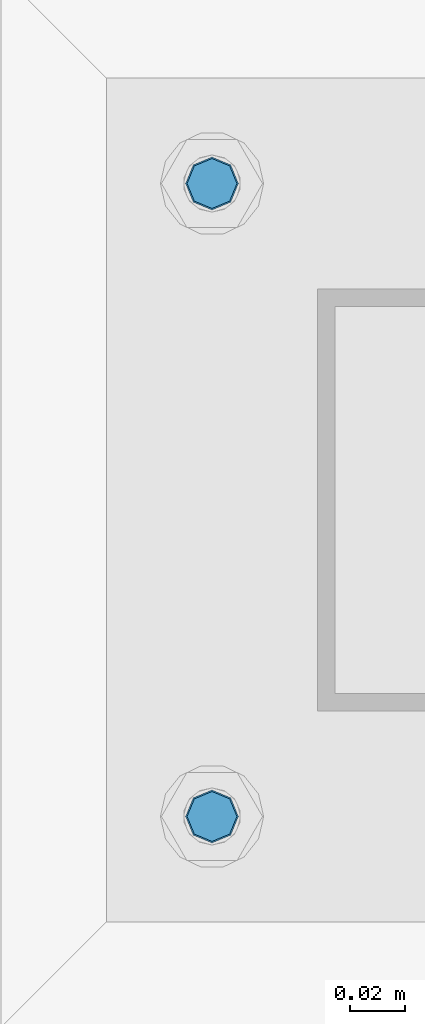
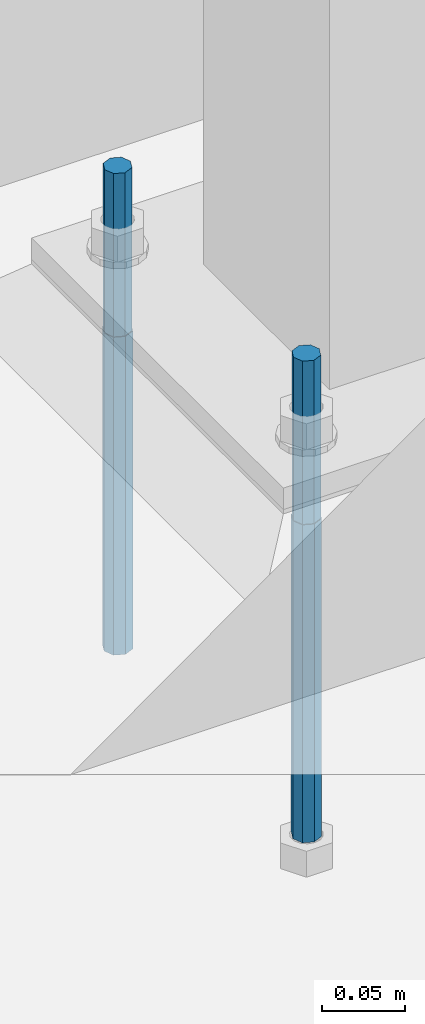
# One storey, part 817 of 1179: 2 beams, 1 element without a shape of its own.
"""IFC2X3 building model written with IfcOpenShell, lengths in millimetres."""

from ifc_helpers import new_model, si_unit, frame, origin_with_axes, place, context, subcontext, project, spatial, faceted_brep, material, type_object, element, aggregate, save


model = new_model("IFC2X3")

# Units and contexts
model_context = context("Model", 3, precision=1e-05, world=origin_with_axes())
body_context = subcontext(model_context, "Body", "Model", "MODEL_VIEW")
ifc_project = project(units=[si_unit("LENGTHUNIT", "METRE", prefix="MILLI"), si_unit("AREAUNIT", "SQUARE_METRE"), si_unit("VOLUMEUNIT", "CUBIC_METRE"), si_unit("MASSUNIT", "GRAM", prefix="KILO"), si_unit("TIMEUNIT", "SECOND"), si_unit("PLANEANGLEUNIT", "RADIAN"), si_unit("SOLIDANGLEUNIT", "STERADIAN"), si_unit("THERMODYNAMICTEMPERATUREUNIT", "DEGREE_CELSIUS"), si_unit("LUMINOUSINTENSITYUNIT", "LUMEN")], contexts=[model_context])

# Site, building, storey
site_placement = place(None, origin_with_axes())
site = spatial("IfcSite", under=ifc_project, at=site_placement, CompositionType="ELEMENT")
building_placement = place(site_placement, origin_with_axes())
building = spatial("IfcBuilding", under=site, at=building_placement, Name="Undefined", CompositionType="ELEMENT")
storey_placement = place(building_placement, origin_with_axes())
storey = spatial("IfcBuildingStorey", under=building, at=storey_placement, Name="Undefined", CompositionType="ELEMENT", Elevation=0.0)

# Assembly, beams
assembly_placement = place(storey_placement, origin_with_axes())
assembly = element("IfcElementAssembly", 1, at=assembly_placement, inside=storey, Name="TEMPLATE", AssemblyPlace="NOTDEFINED", PredefinedType="RIGID_FRAME")
ifc_material = material(Name="STEEL/F1554-GR.36")
beam_type = type_object("IfcBeamType", PredefinedType="NOTDEFINED")
beam_1_placement = place(assembly_placement, frame((26682.7, 2120.9, -812.8), z_axis=(0.0, -1.0, 0.0), x_axis=(0.0, 0.0, -1.0)))
beam_1 = element("IfcBeam", 2, at=beam_1_placement, type_object=beam_type, material=ifc_material, Name="ANCHOR_BOLT", context=body_context, shape_type="Brep", body=[
    faceted_brep([(0.0, -6.73519209080177, -6.73519209080223), (2.95075507493764e-12, -3.62376795237651e-13, -9.52499961853027), (234.949, 0.0, -9.52500000000009), (234.949, -6.73519209080405, -6.73519209080177), (0.0, 6.73519209080177, -6.73519209080223), (234.949, 6.73519209080405, -6.73519209080177), (0.0, 9.52499999999964, 0.0), (234.949, 9.52500000000146, 0.0), (0.0, 6.73519209080177, 6.73519209080223), (234.949, 6.73519209080405, 6.73519209080177), (-9.87109982941227e-13, -3.62376795237651e-13, 9.52499961853027), (234.949, 0.0, 9.52500000000009), (0.0, -6.73519209080177, 6.73519209080223), (234.949, -6.73519209080405, 6.73519209080177), (0.0, -9.52499999999964, 0.0), (234.949, -9.52500000000146, 0.0), (0.0, 6.36396103067818, 6.36396103067909), (0.0, 0.0, 9.0), (0.0, -6.36396103067818, 6.36396103067909), (0.0, -9.0, 0.0), (0.0, -6.36396103067818, -6.36396103067909), (0.0, 0.0, -9.0), (0.0, 6.36396103067818, -6.36396103067909), (0.0, 9.0, 0.0), (-120.65, -6.36396103067818, 6.36396103067909), (-120.65, 0.0, 9.0), (-120.65, 6.36396103067818, 6.36396103067909), (-120.65, 9.0, 0.0), (-120.65, 6.36396103067818, -6.36396103067909), (-120.65, 0.0, -9.0), (-120.65, -6.36396103067818, -6.36396103067909), (-120.65, -9.0, 0.0)], [[[0, 1, 2, 3]], [[1, 4, 5, 2]], [[4, 6, 7, 5]], [[6, 8, 9, 7]], [[8, 10, 11, 9]], [[10, 12, 13, 11]], [[12, 14, 15, 13]], [[2, 5, 7, 9, 11, 13, 15, 3]], [[14, 0, 3, 15]], [[12, 10, 8, 6, 4, 1, 0, 14], [16, 17, 18, 19, 20, 21, 22, 23]], [[24, 25, 26, 27, 28, 29, 30, 31]], [[26, 25, 17, 16]], [[27, 26, 16, 23]], [[28, 27, 23, 22]], [[29, 28, 22, 21]], [[30, 29, 21, 20]], [[31, 30, 20, 19]], [[24, 31, 19, 18]], [[25, 24, 18, 17]]]),
])
beam_2_placement = place(assembly_placement, frame((26682.7, 2349.5, -812.8), z_axis=(0.0, -1.0, 0.0), x_axis=(0.0, 0.0, -1.0)))
beam_2 = element("IfcBeam", 3, at=beam_2_placement, type_object=beam_type, material=ifc_material, Name="ANCHOR_BOLT", context=body_context, shape_type="Brep", body=[
    faceted_brep([(0.0, -6.73519209080177, -6.73519209080223), (2.95075507493764e-12, -3.62376795237651e-13, -9.52499961853027), (234.949, 0.0, -9.52500000000009), (234.949, -6.73519209080405, -6.73519209080177), (0.0, 6.73519209080177, -6.73519209080223), (234.949, 6.73519209080405, -6.73519209080177), (0.0, 9.52499999999964, 0.0), (234.949, 9.52500000000146, 0.0), (0.0, 6.73519209080177, 6.73519209080223), (234.949, 6.73519209080405, 6.73519209080177), (-9.87109982941227e-13, -3.62376795237651e-13, 9.52499961853027), (234.949, 0.0, 9.52500000000009), (0.0, -6.73519209080177, 6.73519209080223), (234.949, -6.73519209080405, 6.73519209080177), (0.0, -9.52499999999964, 0.0), (234.949, -9.52500000000146, 0.0), (0.0, 6.36396103067818, 6.36396103067909), (0.0, 0.0, 9.0), (0.0, -6.36396103067818, 6.36396103067909), (0.0, -9.0, 0.0), (0.0, -6.36396103067818, -6.36396103067909), (0.0, 0.0, -9.0), (0.0, 6.36396103067818, -6.36396103067909), (0.0, 9.0, 0.0), (-120.65, -6.36396103067818, 6.36396103067909), (-120.65, 0.0, 9.0), (-120.65, 6.36396103067818, 6.36396103067909), (-120.65, 9.0, 0.0), (-120.65, 6.36396103067818, -6.36396103067909), (-120.65, 0.0, -9.0), (-120.65, -6.36396103067818, -6.36396103067909), (-120.65, -9.0, 0.0)], [[[0, 1, 2, 3]], [[1, 4, 5, 2]], [[4, 6, 7, 5]], [[6, 8, 9, 7]], [[8, 10, 11, 9]], [[10, 12, 13, 11]], [[12, 14, 15, 13]], [[2, 5, 7, 9, 11, 13, 15, 3]], [[14, 0, 3, 15]], [[12, 10, 8, 6, 4, 1, 0, 14], [16, 17, 18, 19, 20, 21, 22, 23]], [[24, 25, 26, 27, 28, 29, 30, 31]], [[26, 25, 17, 16]], [[27, 26, 16, 23]], [[28, 27, 23, 22]], [[29, 28, 22, 21]], [[30, 29, 21, 20]], [[31, 30, 20, 19]], [[24, 31, 19, 18]], [[25, 24, 18, 17]]]),
])
aggregate(assembly, [beam_1, beam_2])

save(model, "model.ifc")
